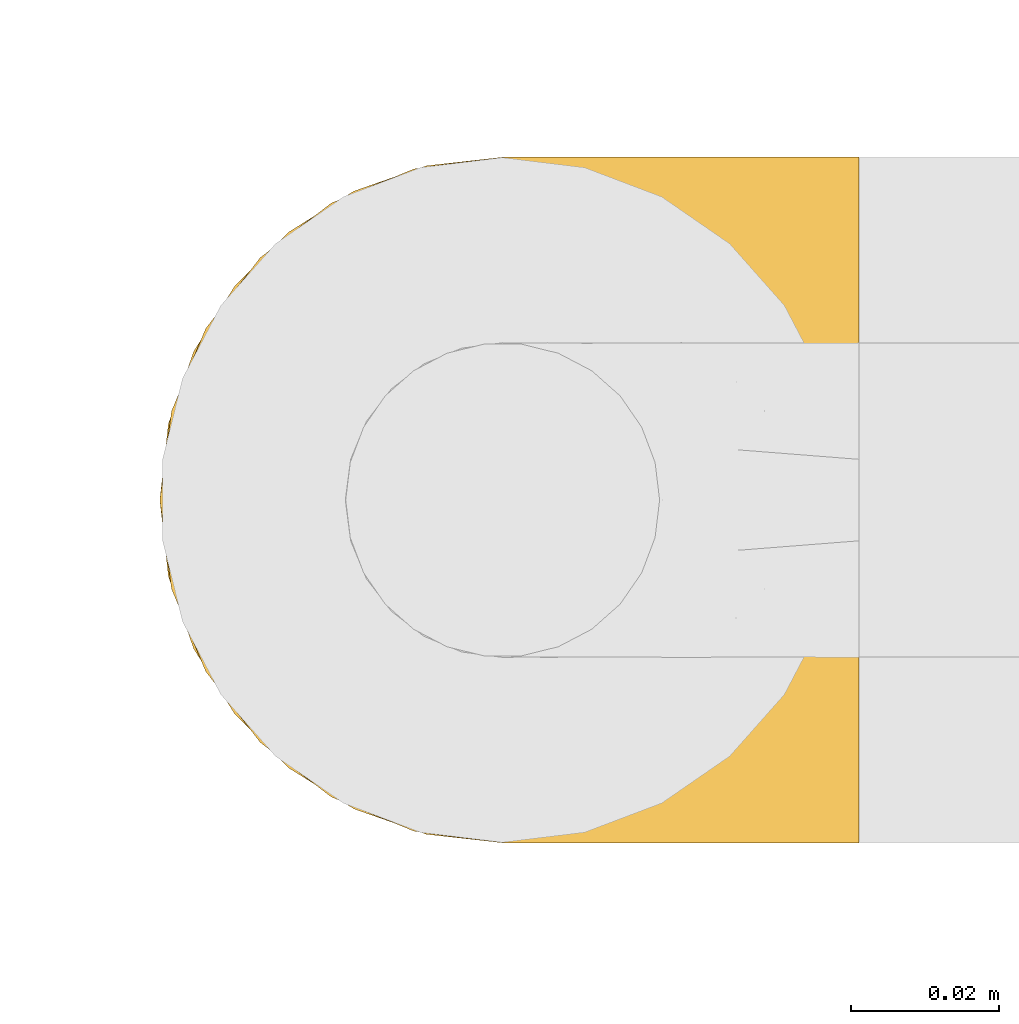
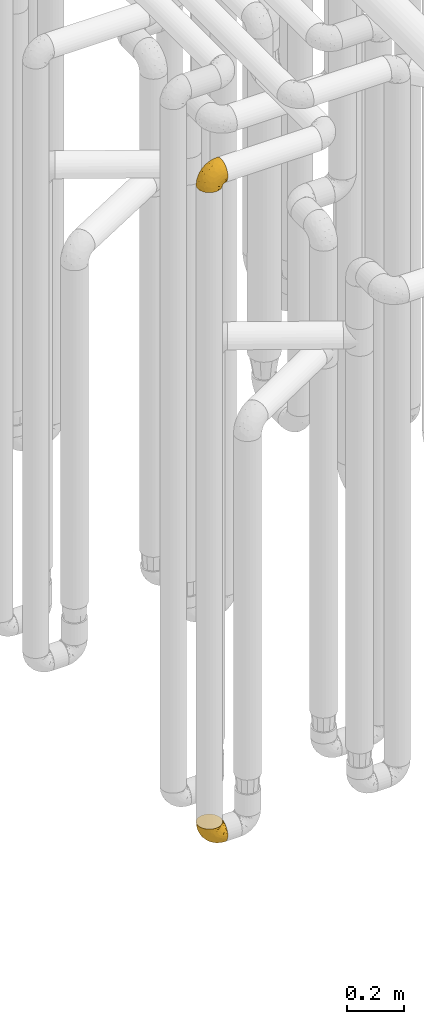
# One storey, part 148 of 827: 2 coverings.
"""IFC2X3 building model written with IfcOpenShell, lengths in millimetres."""

import ifcopenshell
import ifcopenshell.guid

model = None  # the IFC model being written
_history = None  # IfcOwnerHistory: only IFC2X3 demands one
_inside = {}  # id of a spatial element -> (the spatial element, [elements in it])
_under = {}  # id of a project, library or spatial element -> (it, [spatial elements below it])
_declared = {}  # id of a project -> (the project, [libraries it declares])
_typed = {}  # id of a type object -> (the type object, [elements of that type])
_made_of = {}  # id of a material, layer set ... -> (it, [elements and type objects made of it])


def new_model(schema):
    """Start an empty IFC model of exactly this schema.

    Asked for "IFC4X3", IfcOpenShell would pick the latest addendum, in which some entities
    have other attributes; the version numbers below select the first issue.
    IFC2X3 requires an IfcOwnerHistory on every rooted entity: one is made here for all.
    """
    global model, _history
    if schema == "IFC4X3":
        model = ifcopenshell.file(schema_version=(4, 3, 0, 0))
    else:
        model = ifcopenshell.file(schema=schema)
    _inside.clear()
    _under.clear()
    _declared.clear()
    _typed.clear()
    _made_of.clear()
    _history = None
    if model.schema == "IFC2X3":
        org = make("IfcOrganization", Name="unknown")
        user = make(
            "IfcPersonAndOrganization",
            ThePerson=make("IfcPerson", FamilyName="unknown"),
            TheOrganization=org,
        )
        app = make(
            "IfcApplication",
            ApplicationDeveloper=org,
            Version="unknown",
            ApplicationFullName="unknown",
            ApplicationIdentifier="unknown",
        )
        _history = make(
            "IfcOwnerHistory",
            OwningUser=user,
            OwningApplication=app,
            ChangeAction="ADDED",
            CreationDate=0,
        )
    return model


def make(cls, **values):
    """One entity of the class cls with the attributes given. An attribute that is None is left unset."""
    return model.create_entity(
        cls, **{name: value for name, value in values.items() if value is not None}
    )


def entity(cls, *values):
    """Any entity or typed value of the class cls, its attributes in the order of the schema. None: left unset."""
    e = model.create_entity(cls)
    for i, value in enumerate(values):
        if value is not None:
            e[i] = value
    return e


def rooted(cls, **values):
    """An entity with a GlobalId (a new one), such as an element, a storey or a relation."""
    return make(cls, GlobalId=ifcopenshell.guid.new(), OwnerHistory=_history, **values)


def si_unit(unit_type, name, prefix=None):
    """IfcSIUnit, for example si_unit("LENGTHUNIT", "METRE", prefix="MILLI")."""
    return make("IfcSIUnit", UnitType=unit_type, Prefix=prefix, Name=name)


def converted_unit(unit_type, name, factor, base, dimensions=None, offset=None):
    """IfcConversionBasedUnit, such as the inch: factor (a typed value) times the base unit."""
    return make(
        "IfcConversionBasedUnit"
        if offset is None
        else "IfcConversionBasedUnitWithOffset",
        ConversionOffset=offset,
        Dimensions=None
        if dimensions is None
        else entity("IfcDimensionalExponents", *dimensions),
        UnitType=unit_type,
        Name=name,
        ConversionFactor=make(
            "IfcMeasureWithUnit", ValueComponent=factor, UnitComponent=base
        ),
    )


def derived_unit(unit_type, elements):
    """IfcDerivedUnit: a product of units, each with its exponent."""
    return make(
        "IfcDerivedUnit",
        Elements=[
            make("IfcDerivedUnitElement", Unit=unit, Exponent=power)
            for unit, power in elements
        ],
        UnitType=unit_type,
    )


def assignment(units):
    """IfcUnitAssignment: the units of a project."""
    return None if units is None else make("IfcUnitAssignment", Units=units)


def point(xyz):
    """IfcCartesianPoint."""
    return None if xyz is None else make("IfcCartesianPoint", Coordinates=xyz)


def direction(xyz):
    """IfcDirection."""
    return None if xyz is None else make("IfcDirection", DirectionRatios=xyz)


def frame(location, z_axis=None, x_axis=None):
    """IfcAxis2Placement3D, a coordinate frame: its origin and axes. An axis left out is left unset."""
    return make(
        "IfcAxis2Placement3D",
        Location=point(location),
        Axis=direction(z_axis),
        RefDirection=direction(x_axis),
    )


def origin():
    """The frame at (0, 0, 0) with its axes left unset."""
    return frame((0.0, 0.0, 0.0))


def place(relative_to, where):
    """IfcLocalPlacement: puts the frame where relative to a parent placement (None: the world)."""
    return make(
        "IfcLocalPlacement", PlacementRelTo=relative_to, RelativePlacement=where
    )


def context(
    kind, dimensions, precision=None, world=None, true_north=None, identifier=None
):
    """IfcGeometricRepresentationContext, for example the 3D "Model" context."""
    return make(
        "IfcGeometricRepresentationContext",
        ContextIdentifier=identifier,
        ContextType=kind,
        CoordinateSpaceDimension=dimensions,
        Precision=precision,
        WorldCoordinateSystem=world,
        TrueNorth=true_north,
    )


def subcontext(parent, identifier, kind, view, scale=None):
    """IfcGeometricRepresentationSubContext, for example "Body" below "Model"."""
    return make(
        "IfcGeometricRepresentationSubContext",
        ContextIdentifier=identifier,
        ContextType=kind,
        ParentContext=parent,
        TargetScale=scale,
        TargetView=view,
    )


def project(units=None, contexts=None):
    """IfcProject with its units and contexts."""
    return rooted(
        "IfcProject",
        Name="project",
        RepresentationContexts=contexts,
        UnitsInContext=assignment(units),
    )


def spatial(cls, under=None, at=None, **own):
    """A site, building, storey or space (cls), placed at a placement, below another one or the project."""
    s = rooted(cls, ObjectPlacement=at, **own)
    if under is not None:
        _under.setdefault(under.id(), (under, []))[1].append(s)
    return s


def faces_of(points, faces, orient=None, outer=None):
    """IfcFace entities. A face is a list of loops; a loop is a list of indices into points, from 0.

    orient and outer hold one flag for each loop. By default every Orientation is true, the
    first loop of a face is its IfcFaceOuterBound and the others are IfcFaceBound.
    """
    made = []
    for i, loops in enumerate(faces):
        bounds = []
        for j, loop in enumerate(loops):
            is_outer = j == 0 if outer is None else outer[i][j]
            bounds.append(
                make(
                    "IfcFaceOuterBound" if is_outer else "IfcFaceBound",
                    Bound=make("IfcPolyLoop", Polygon=[points[k] for k in loop]),
                    Orientation=True if orient is None else orient[i][j],
                )
            )
        made.append(make("IfcFace", Bounds=bounds))
    return made


def faceted_brep(points, faces, orient=None, outer=None, voids=None):
    """IfcFacetedBrep: a solid bounded by flat faces; with voids (closed shells), ...WithVoids."""
    shared = [point(p) for p in points]
    hull = make("IfcClosedShell", CfsFaces=faces_of(shared, faces, orient, outer))
    if voids is None:
        return make("IfcFacetedBrep", Outer=hull)
    return make(
        "IfcFacetedBrepWithVoids",
        Outer=hull,
        Voids=[
            make(cls, CfsFaces=faces_of(shared, fs, o, b)) for cls, fs, o, b in voids
        ],
    )


def shape(context_of_items, identifier, shape_type, items):
    """IfcShapeRepresentation: the items that make up one representation, for example the "Body"."""
    return make(
        "IfcShapeRepresentation",
        ContextOfItems=context_of_items,
        RepresentationIdentifier=identifier,
        RepresentationType=shape_type,
        Items=items,
    )


def made_of(thing, what):
    """Note that an element or type object is made of a material, layer set ...; save() writes the relation."""
    if what is not None:
        _made_of.setdefault(what.id(), (what, []))[1].append(thing)
    return thing


def element(
    cls,
    number,
    at=None,
    inside=None,
    cuts=None,
    type_object=None,
    material=None,
    context=None,
    identifier="Body",
    shape_type=None,
    held_by="IfcProductDefinitionShape",
    body=None,
    shapes=None,
    **own,
):
    """One element of the class cls, such as IfcWall. Its Tag is "e" and its number.

    at: its placement. inside: the storey or other place that contains it. cuts: it is an
    opening in that element (IfcRelVoidsElement). A single representation is given by context,
    identifier, shape_type and body (its items); several are given by shapes. held_by: the class
    of the entity that holds the representations. save() writes the other relations.
    """
    e = rooted(cls, Tag="e%d" % number, ObjectPlacement=at, **own)
    if body is not None:
        shapes = [shape(context, identifier, shape_type, body)]
    if shapes is not None:
        e.Representation = make(held_by, Representations=shapes)
    if inside is not None:
        _inside.setdefault(inside.id(), (inside, []))[1].append(e)
    if cuts is not None:
        rooted(
            "IfcRelVoidsElement", RelatingBuildingElement=cuts, RelatedOpeningElement=e
        )
    if type_object is not None:
        _typed.setdefault(type_object.id(), (type_object, []))[1].append(e)
    return made_of(e, material)


def aggregate(whole, parts):
    """IfcRelAggregates: a whole, such as a stair, and the parts it consists of."""
    return rooted("IfcRelAggregates", RelatingObject=whole, RelatedObjects=parts)


def save(model, path):
    """Write the relations noted so far, then the file.

    IfcRelAggregates (storeys below a building ...), IfcRelContainedInSpatialStructure (elements
    in a storey), IfcRelDefinesByType, IfcRelAssociatesMaterial and IfcRelDeclares: one each for
    every whole, place, type object, material and project.
    """
    for whole, parts in _under.values():
        aggregate(whole, parts)
    for where, things in _inside.values():
        rooted(
            "IfcRelContainedInSpatialStructure",
            RelatedElements=things,
            RelatingStructure=where,
        )
    for kind, things in _typed.values():
        rooted("IfcRelDefinesByType", RelatedObjects=things, RelatingType=kind)
    for what, things in _made_of.values():
        rooted("IfcRelAssociatesMaterial", RelatedObjects=things, RelatingMaterial=what)
    for by, libraries in _declared.values():
        rooted("IfcRelDeclares", RelatingContext=by, RelatedDefinitions=libraries)
    model.write(path)


model = new_model("IFC2X3")

# Units and contexts
model_context = context("Model", 3, precision=0.01, world=origin(), true_north=direction((6.12303176911189e-17, 1.0)))
body_context = subcontext(model_context, "Body", "Model", "MODEL_VIEW")
ifc_project = project(units=[si_unit("LENGTHUNIT", "METRE", prefix="MILLI"), si_unit("AREAUNIT", "SQUARE_METRE"), si_unit("VOLUMEUNIT", "CUBIC_METRE"), converted_unit("PLANEANGLEUNIT", "DEGREE", entity("IfcRatioMeasure", 0.0174532925199433), si_unit("PLANEANGLEUNIT", "RADIAN"), dimensions=[0, 0, 0, 0, 0, 0, 0]), si_unit("MASSUNIT", "GRAM", prefix="KILO"), derived_unit("MASSDENSITYUNIT", [(si_unit("MASSUNIT", "GRAM", prefix="KILO"), 1), (si_unit("LENGTHUNIT", "METRE"), -3)]), derived_unit("MOMENTOFINERTIAUNIT", [(si_unit("LENGTHUNIT", "METRE"), 4)]), si_unit("TIMEUNIT", "SECOND"), si_unit("FREQUENCYUNIT", "HERTZ"), si_unit("THERMODYNAMICTEMPERATUREUNIT", "DEGREE_CELSIUS"), derived_unit("THERMALTRANSMITTANCEUNIT", [(si_unit("MASSUNIT", "GRAM", prefix="KILO"), 1), (si_unit("THERMODYNAMICTEMPERATUREUNIT", "KELVIN"), -1), (si_unit("TIMEUNIT", "SECOND"), -3)]), derived_unit("VOLUMETRICFLOWRATEUNIT", [(si_unit("LENGTHUNIT", "METRE"), 3), (si_unit("TIMEUNIT", "SECOND"), -1)]), derived_unit("MASSFLOWRATEUNIT", [(si_unit("MASSUNIT", "GRAM", prefix="KILO"), 1), (si_unit("TIMEUNIT", "SECOND"), -1)]), derived_unit("ROTATIONALFREQUENCYUNIT", [(si_unit("TIMEUNIT", "SECOND"), -1)]), si_unit("ELECTRICCURRENTUNIT", "AMPERE"), si_unit("ELECTRICVOLTAGEUNIT", "VOLT"), si_unit("POWERUNIT", "WATT"), si_unit("FORCEUNIT", "NEWTON", prefix="KILO"), si_unit("ILLUMINANCEUNIT", "LUX"), si_unit("LUMINOUSFLUXUNIT", "LUMEN"), si_unit("LUMINOUSINTENSITYUNIT", "CANDELA"), derived_unit("USERDEFINED", [(si_unit("MASSUNIT", "GRAM", prefix="KILO"), -1), (si_unit("LENGTHUNIT", "METRE"), -2), (si_unit("TIMEUNIT", "SECOND"), 3), (si_unit("LUMINOUSFLUXUNIT", "LUMEN"), 1)]), derived_unit("LINEARVELOCITYUNIT", [(si_unit("LENGTHUNIT", "METRE"), 1), (si_unit("TIMEUNIT", "SECOND"), -1)]), si_unit("PRESSUREUNIT", "PASCAL"), derived_unit("USERDEFINED", [(si_unit("LENGTHUNIT", "METRE"), -2), (si_unit("MASSUNIT", "GRAM", prefix="KILO"), 1), (si_unit("TIMEUNIT", "SECOND"), -2)]), derived_unit("LINEARFORCEUNIT", [(si_unit("MASSUNIT", "GRAM", prefix="KILO"), 1), (si_unit("LENGTHUNIT", "METRE"), 1), (si_unit("TIMEUNIT", "SECOND"), -2), (si_unit("LENGTHUNIT", "METRE"), -1)]), derived_unit("PLANARFORCEUNIT", [(si_unit("MASSUNIT", "GRAM", prefix="KILO"), 1), (si_unit("LENGTHUNIT", "METRE"), 1), (si_unit("TIMEUNIT", "SECOND"), -2), (si_unit("LENGTHUNIT", "METRE"), -2)])], contexts=[model_context])

# Site, building, storey
site_placement = place(None, origin())
site = spatial("IfcSite", under=ifc_project, at=site_placement, CompositionType="ELEMENT")
building_placement = place(site_placement, origin())
building = spatial("IfcBuilding", under=site, at=building_placement, CompositionType="ELEMENT")
storey_placement = place(building_placement, frame((0.0, 0.0, 28200.0)))
storey = spatial("IfcBuildingStorey", under=building, at=storey_placement, Name="08", CompositionType="ELEMENT", Elevation=28200.0)

# Coverings
covering_1_placement = place(storey_placement, frame((35077.24, 10309.29, 352.2)))
element("IfcCovering", 1, at=covering_1_placement, inside=storey, Name=":ADSK_", ObjectType=":ADSK_", PredefinedType="INSULATION", context=body_context, shape_type="Brep", body=[
    faceted_brep([(18.98, 83.91, 95.8), (11.67, 76.59, 95.8), (6.17, 67.83, 95.8), (2.75, 58.07, 95.8), (1.6, 47.8, 95.8), (2.75, 37.51, 95.8), (6.17, 27.74, 95.8), (11.68, 18.98, 95.8), (19.0, 11.67, 95.8), (27.76, 6.17, 95.8), (37.52, 2.75, 95.8), (47.8, 1.6, 95.8), (51.94, 2.06, 95.8), (55.01, 2.41, 95.8), (58.08, 2.75, 95.8), (62.96, 4.46, 95.8), (67.85, 6.17, 95.8), (72.23, 8.93, 95.8), (76.61, 11.68, 95.8), (80.26, 15.34, 95.8), (83.92, 19.0, 95.8), (89.42, 27.76, 95.8), (91.13, 32.64, 95.8), (92.84, 37.52, 95.8), (94.0, 47.8, 95.8), (92.84, 58.08, 95.8), (91.13, 62.96, 95.8), (89.42, 67.85, 95.8), (83.91, 76.61, 95.8), (80.25, 80.26, 95.8), (76.59, 83.92, 95.8), (72.21, 86.67, 95.8), (67.83, 89.42, 95.8), (62.95, 91.13, 95.8), (58.07, 92.84, 95.8), (55.0, 93.18, 95.8), (51.94, 93.53, 95.8), (47.8, 94.0, 95.8), (37.51, 92.84, 95.8), (27.74, 89.42, 95.8), (95.8, 47.8, 94.0), (95.8, 35.84, 92.42), (95.8, 24.7, 87.81), (95.8, 19.91, 84.13), (95.8, 15.13, 80.46), (95.8, 11.46, 75.68), (95.8, 7.78, 70.9), (95.8, 5.48, 65.32), (95.8, 3.17, 59.75), (95.8, 2.69, 56.14), (95.8, 2.42, 54.06), (95.8, 2.14, 51.97), (95.8, 1.6, 47.8), (95.8, 3.17, 35.84), (95.8, 7.78, 24.7), (95.8, 15.13, 15.13), (95.8, 24.7, 7.78), (95.8, 35.84, 3.17), (95.8, 47.8, 1.6), (95.8, 59.75, 3.17), (95.8, 70.9, 7.78), (95.8, 80.46, 15.13), (95.8, 87.81, 24.7), (95.8, 92.42, 35.84), (95.8, 94.0, 47.8), (95.8, 93.45, 51.97), (95.8, 92.9, 56.14), (95.8, 92.42, 59.75), (95.8, 90.11, 65.32), (95.8, 87.81, 70.9), (95.8, 84.13, 75.68), (95.8, 80.46, 80.46), (95.8, 75.68, 84.13), (95.8, 70.9, 87.81), (95.8, 59.75, 92.42), (60.58, 71.98, 15.84), (74.11, 63.6, 6.99), (51.59, 59.72, 14.39), (66.69, 47.8, 6.21), (76.19, 55.16, 4.26), (84.43, 47.8, 3.39), (31.2, 63.76, 31.2), (42.88, 72.22, 26.47), (79.41, 74.18, 11.44), (60.7, 92.52, 47.66), (61.85, 94.0, 61.85), (65.75, 94.0, 59.25), (69.64, 94.0, 56.65), (73.53, 94.0, 54.05), (77.43, 94.0, 51.45), (74.59, 82.14, 19.8), (54.72, 80.34, 26.22), (64.18, 87.52, 31.58), (37.94, 79.59, 38.36), (25.89, 78.25, 51.54), (34.73, 85.01, 51.6), (42.89, 90.25, 55.97), (49.83, 93.2, 62.88), (48.58, 87.23, 41.35), (22.41, 85.55, 82.24), (78.69, 93.0, 40.88), (81.64, 89.31, 29.0), (6.22, 61.31, 74.06), (12.11, 56.86, 54.53), (14.81, 68.34, 57.98), (21.61, 65.71, 43.81), (22.41, 56.99, 38.22), (30.12, 72.15, 38.33), (10.01, 70.34, 74.76), (15.36, 78.36, 76.85), (3.39, 47.8, 84.43), (19.59, 47.8, 40.43), (30.01, 47.8, 30.01), (41.19, 93.06, 78.67), (48.54, 94.0, 92.06), (49.28, 94.0, 88.32), (49.82, 94.0, 85.6), (50.37, 94.0, 82.88), (50.91, 94.0, 80.15), (51.45, 94.0, 77.43), (31.61, 89.88, 76.36), (80.15, 94.0, 50.91), (82.88, 94.0, 50.37), (85.6, 94.0, 49.82), (88.32, 94.0, 49.28), (90.19, 94.0, 48.91), (92.06, 94.0, 48.54), (6.21, 47.8, 66.69), (54.05, 94.0, 73.53), (56.65, 94.0, 69.64), (59.25, 94.0, 65.75), (24.66, 83.7, 66.13), (40.43, 47.8, 19.59), (35.17, 55.9, 24.64), (12.9, 47.8, 53.56), (53.56, 47.8, 12.9), (85.34, 81.75, 82.81), (78.44, 86.43, 81.22), (84.37, 79.8, 86.57), (89.05, 69.84, 92.75), (82.76, 79.5, 89.68), (86.31, 88.08, 72.26), (83.73, 91.6, 64.73), (77.31, 92.93, 62.45), (87.78, 92.43, 60.63), (87.91, 93.24, 56.91), (81.29, 93.36, 58.14), (93.97, 57.25, 93.7), (70.76, 89.41, 83.4), (63.67, 92.89, 75.54), (62.62, 92.66, 79.46), (90.64, 79.58, 82.28), (84.08, 86.51, 76.25), (76.28, 86.29, 84.69), (77.45, 83.91, 90.18), (88.72, 90.94, 65.12), (71.28, 91.94, 71.71), (68.09, 91.98, 75.21), (91.07, 82.79, 78.6), (57.47, 93.16, 87.27), (70.34, 88.76, 87.92), (91.35, 73.94, 86.94), (62.99, 91.89, 86.1), (94.52, 47.8, 94.52), (76.47, 92.22, 66.23), (69.96, 88.56, 91.08), (89.86, 87.72, 71.77), (78.94, 88.33, 76.21), (73.51, 92.18, 68.59), (89.62, 71.78, 89.94), (84.09, 9.09, 76.25), (86.3, 7.51, 72.26), (91.06, 12.8, 78.6), (88.32, 1.6, 49.28), (92.06, 1.6, 48.54), (82.88, 1.6, 50.37), (85.6, 1.6, 49.82), (93.97, 38.35, 93.7), (89.63, 23.84, 89.95), (50.37, 1.6, 82.88), (49.82, 1.6, 85.6), (48.54, 1.6, 92.06), (49.28, 1.6, 88.32), (82.77, 16.1, 89.68), (70.36, 6.84, 87.92), (77.31, 2.66, 62.45), (76.47, 3.37, 66.24), (69.64, 1.6, 56.65), (65.75, 1.6, 59.25), (87.78, 3.16, 60.63), (87.91, 2.35, 56.91), (89.06, 25.77, 92.76), (90.65, 16.02, 82.28), (85.35, 13.85, 82.81), (73.53, 1.6, 54.05), (77.43, 1.6, 51.45), (81.29, 2.23, 58.14), (77.46, 11.69, 90.18), (76.29, 9.31, 84.7), (57.47, 2.43, 87.25), (63.71, 2.71, 75.58), (68.11, 3.61, 75.2), (70.77, 6.18, 83.39), (71.31, 3.66, 71.7), (78.46, 9.17, 81.22), (69.52, 6.77, 90.73), (62.64, 2.93, 79.47), (91.35, 21.66, 86.94), (59.25, 1.6, 65.75), (84.6, 16.09, 86.75), (62.98, 3.7, 86.08), (51.45, 1.6, 77.43), (54.05, 1.6, 73.53), (56.65, 1.6, 69.64), (83.73, 3.99, 64.73), (80.15, 1.6, 50.91), (88.72, 4.65, 65.12), (61.85, 1.6, 61.85), (73.56, 3.43, 68.62), (78.96, 7.27, 76.22), (91.36, 9.46, 74.03), (50.91, 1.6, 80.15), (62.87, 2.4, 49.81), (76.19, 40.43, 4.26), (73.57, 13.57, 19.95), (56.07, 11.3, 30.61), (49.77, 18.65, 25.71), (44.73, 27.26, 22.43), (60.58, 23.61, 15.85), (47.64, 3.07, 60.69), (78.32, 2.69, 40.49), (51.59, 35.87, 14.39), (74.11, 31.99, 6.99), (76.04, 6.71, 29.56), (79.41, 21.41, 11.45), (14.82, 27.24, 57.98), (6.22, 34.26, 74.06), (12.12, 38.73, 54.52), (23.51, 26.97, 43.47), (31.2, 31.83, 31.2), (34.96, 23.4, 33.27), (33.86, 6.91, 64.26), (38.94, 3.4, 74.29), (30.23, 5.84, 80.41), (35.17, 39.69, 24.64), (15.85, 17.6, 73.62), (22.59, 10.38, 78.98), (21.56, 20.6, 53.69), (55.94, 5.36, 42.86), (20.67, 35.73, 41.67), (9.19, 24.84, 79.66), (25.79, 13.87, 58.41), (41.16, 9.06, 47.11), (37.95, 15.99, 38.37)], [[[0, 1, 2, 3, 4, 5, 6, 7, 8, 9, 10, 11, 12, 13, 14, 15, 16, 17, 18, 19, 20, 21, 22, 23, 24, 25, 26, 27, 28, 29, 30, 31, 32, 33, 34, 35, 36, 37, 38, 39]], [[40, 41, 42, 43, 44, 45, 46, 47, 48, 49, 50, 51, 52, 53, 54, 55, 56, 57, 58, 59, 60, 61, 62, 63, 64, 65, 66, 67, 68, 69, 70, 71, 72, 73, 74]], [[75, 76, 77]], [[78, 79, 80]], [[77, 81, 82]], [[76, 75, 83]], [[84, 85, 86, 87, 88, 89]], [[90, 91, 92]], [[76, 60, 59]], [[93, 94, 95]], [[90, 62, 61]], [[83, 61, 60]], [[96, 97, 84]], [[98, 93, 95]], [[0, 39, 99]], [[100, 84, 89]], [[62, 101, 63]], [[2, 102, 3]], [[92, 84, 100]], [[103, 102, 104]], [[103, 105, 106]], [[93, 107, 94]], [[1, 108, 2]], [[92, 101, 90]], [[108, 1, 109]], [[102, 110, 3]], [[93, 82, 107]], [[102, 108, 104]], [[111, 106, 112]], [[109, 0, 99]], [[113, 37, 114, 115, 116, 117, 118, 119]], [[120, 38, 113]], [[100, 89, 121, 122, 123, 124, 125, 126, 64]], [[127, 102, 103]], [[97, 119, 128, 129, 130, 85]], [[99, 120, 131]], [[132, 133, 77]], [[59, 80, 79]], [[1, 0, 109]], [[98, 84, 92]], [[94, 109, 131]], [[120, 39, 38]], [[93, 91, 82]], [[104, 94, 105]], [[97, 113, 119]], [[95, 120, 96]], [[83, 90, 61]], [[91, 93, 98]], [[64, 63, 100]], [[100, 63, 101]], [[77, 76, 79]], [[133, 106, 81]], [[84, 97, 85]], [[113, 96, 120]], [[113, 97, 96]], [[37, 113, 38]], [[110, 102, 127]], [[110, 4, 3]], [[103, 111, 134, 127]], [[90, 75, 91]], [[82, 81, 107]], [[91, 75, 82]], [[77, 82, 75]], [[76, 83, 60]], [[90, 83, 75]], [[105, 107, 81]], [[94, 131, 95]], [[105, 94, 107]], [[109, 94, 104]], [[120, 95, 131]], [[98, 95, 96]], [[84, 98, 96]], [[98, 92, 91]], [[106, 105, 81]], [[103, 104, 105]], [[112, 106, 133]], [[103, 106, 111]], [[112, 133, 132]], [[81, 77, 133]], [[77, 78, 135, 132]], [[120, 99, 39]], [[109, 99, 131]], [[59, 58, 80]], [[59, 79, 76]], [[90, 101, 62]], [[100, 101, 92]], [[2, 108, 102]], [[109, 104, 108]], [[78, 77, 79]], [[136, 137, 138]], [[27, 139, 140]], [[141, 142, 143]], [[144, 145, 121]], [[146, 89, 88]], [[147, 139, 25]], [[148, 149, 150]], [[136, 151, 152]], [[147, 40, 74]], [[24, 147, 25]], [[140, 153, 154]], [[33, 116, 34]], [[73, 72, 151]], [[114, 37, 36, 35, 34, 116, 115]], [[146, 155, 144]], [[156, 85, 130]], [[157, 149, 148]], [[151, 158, 152]], [[117, 33, 159]], [[29, 154, 160]], [[161, 74, 73]], [[162, 128, 119]], [[66, 65, 64, 126, 125, 124, 123, 122, 67]], [[163, 147, 24]], [[27, 140, 28]], [[149, 129, 150]], [[139, 27, 26, 25]], [[68, 144, 69]], [[129, 128, 150]], [[164, 87, 86]], [[130, 129, 149]], [[122, 145, 67]], [[154, 153, 148]], [[162, 119, 159]], [[165, 30, 160]], [[150, 160, 148]], [[128, 162, 150]], [[30, 165, 31]], [[145, 144, 68]], [[89, 146, 144]], [[87, 164, 143]], [[166, 155, 142]], [[88, 87, 143]], [[162, 160, 150]], [[160, 30, 29]], [[154, 29, 28]], [[140, 154, 28]], [[160, 154, 148]], [[140, 137, 153]], [[157, 148, 153]], [[156, 130, 157]], [[153, 137, 157]], [[157, 137, 156]], [[167, 137, 136]], [[168, 85, 156]], [[152, 168, 167]], [[167, 168, 156]], [[164, 152, 141]], [[71, 158, 72]], [[152, 167, 136]], [[88, 142, 146]], [[144, 155, 69]], [[146, 142, 155]], [[70, 166, 71]], [[142, 141, 166]], [[70, 69, 155]], [[141, 158, 71]], [[161, 73, 151]], [[138, 137, 140]], [[161, 136, 169]], [[136, 161, 151]], [[74, 161, 169]], [[152, 158, 141]], [[151, 72, 158]], [[168, 152, 164]], [[137, 167, 156]], [[164, 86, 168]], [[85, 168, 86]], [[116, 33, 117]], [[130, 149, 157]], [[67, 145, 68]], [[121, 89, 144]], [[145, 122, 121]], [[40, 147, 163]], [[169, 147, 74]], [[159, 33, 32]], [[162, 159, 32]], [[159, 119, 118, 117]], [[139, 147, 169]], [[139, 169, 138]], [[162, 32, 31]], [[141, 143, 164]], [[88, 143, 142]], [[71, 166, 141]], [[155, 166, 70]], [[139, 138, 140]], [[169, 136, 138]], [[160, 162, 165]], [[162, 31, 165]], [[170, 171, 172]], [[173, 174, 52, 51, 50, 49, 48, 175, 176]], [[177, 178, 41]], [[179, 15, 180]], [[12, 11, 181, 182, 180, 14, 13]], [[183, 21, 20]], [[19, 18, 184]], [[185, 186, 187]], [[186, 188, 187]], [[43, 172, 44]], [[189, 190, 47]], [[23, 22, 21, 191]], [[170, 192, 193]], [[40, 163, 177]], [[194, 195, 196]], [[24, 23, 177]], [[197, 198, 183]], [[199, 15, 179]], [[47, 46, 189]], [[200, 201, 202]], [[201, 203, 204]], [[205, 206, 184]], [[207, 41, 178]], [[16, 15, 199]], [[14, 180, 15]], [[202, 201, 198]], [[208, 201, 200]], [[163, 24, 177]], [[48, 47, 190]], [[196, 195, 189]], [[197, 184, 202]], [[204, 193, 209]], [[210, 211, 212]], [[206, 212, 213]], [[205, 17, 210]], [[184, 206, 202]], [[210, 212, 206]], [[185, 194, 214]], [[189, 215, 190]], [[216, 45, 214]], [[186, 171, 170]], [[189, 216, 196]], [[197, 20, 19]], [[194, 185, 187]], [[197, 183, 20]], [[184, 197, 19]], [[197, 202, 198]], [[206, 200, 202]], [[204, 183, 198]], [[201, 208, 203]], [[203, 208, 217]], [[204, 198, 201]], [[217, 188, 218]], [[193, 219, 170]], [[171, 186, 185]], [[170, 218, 186]], [[170, 219, 218]], [[42, 207, 192]], [[171, 220, 172]], [[216, 189, 46]], [[214, 194, 196]], [[44, 220, 45]], [[214, 196, 216]], [[216, 46, 45]], [[214, 45, 220]], [[192, 43, 42]], [[204, 203, 219]], [[207, 193, 192]], [[209, 193, 178]], [[41, 207, 42]], [[193, 207, 178]], [[43, 192, 172]], [[170, 172, 192]], [[204, 219, 193]], [[219, 203, 218]], [[217, 218, 203]], [[188, 186, 218]], [[206, 213, 200]], [[208, 200, 213]], [[199, 210, 16]], [[215, 189, 195]], [[215, 175, 190]], [[175, 48, 190]], [[199, 179, 221, 211]], [[210, 199, 211]], [[23, 191, 177]], [[40, 177, 41]], [[178, 177, 191]], [[21, 183, 191]], [[209, 191, 183]], [[205, 18, 17]], [[17, 16, 210]], [[171, 185, 214]], [[172, 220, 44]], [[214, 220, 171]], [[191, 209, 178]], [[204, 209, 183]], [[206, 205, 210]], [[18, 205, 184]], [[222, 195, 194, 187, 188, 217]], [[57, 223, 80]], [[224, 225, 226]], [[226, 227, 228]], [[229, 217, 208, 213, 212, 211]], [[230, 52, 174, 173, 176, 175, 215, 195]], [[231, 232, 228]], [[231, 78, 223]], [[223, 57, 232]], [[224, 233, 225]], [[233, 54, 53]], [[234, 232, 56]], [[56, 55, 234]], [[234, 224, 228]], [[235, 236, 237]], [[224, 55, 54]], [[238, 239, 240]], [[52, 230, 53]], [[241, 242, 243]], [[227, 244, 231]], [[11, 10, 242]], [[236, 6, 5]], [[7, 245, 8]], [[8, 246, 9]], [[238, 247, 235]], [[222, 229, 248]], [[242, 211, 221, 179, 180, 182, 181, 11]], [[233, 53, 230]], [[111, 112, 249]], [[250, 6, 236]], [[246, 251, 241]], [[6, 250, 7]], [[127, 236, 110]], [[248, 229, 252]], [[246, 8, 245]], [[235, 245, 250]], [[236, 5, 110]], [[235, 249, 238]], [[237, 236, 127]], [[243, 9, 246]], [[252, 229, 241]], [[56, 232, 57]], [[222, 230, 195]], [[225, 248, 252]], [[248, 233, 230]], [[54, 233, 224]], [[231, 228, 227]], [[244, 132, 231]], [[248, 225, 233]], [[226, 225, 253]], [[235, 250, 236]], [[245, 7, 250]], [[251, 246, 245]], [[243, 246, 241]], [[247, 245, 235]], [[252, 251, 253]], [[229, 222, 217]], [[230, 222, 248]], [[5, 4, 110]], [[237, 127, 134, 111]], [[238, 249, 239]], [[224, 234, 55]], [[232, 234, 228]], [[242, 241, 229]], [[10, 9, 243]], [[211, 242, 229]], [[10, 243, 242]], [[80, 223, 78]], [[80, 58, 57]], [[231, 223, 232]], [[227, 240, 239]], [[224, 226, 228]], [[240, 226, 253]], [[227, 239, 244]], [[226, 240, 227]], [[251, 247, 253]], [[240, 253, 247]], [[249, 235, 237]], [[237, 111, 249]], [[112, 132, 244]], [[112, 244, 249]], [[78, 231, 132, 135]], [[249, 244, 239]], [[247, 238, 240]], [[245, 247, 251]], [[251, 252, 241]], [[225, 252, 253]]]),
])
covering_2_placement = place(storey_placement, frame((35077.24, 10309.29, 3150.4)))
element("IfcCovering", 2, at=covering_2_placement, inside=storey, Name=":ADSK_", ObjectType=":ADSK_", PredefinedType="INSULATION", context=body_context, shape_type="Brep", body=[
    faceted_brep([(95.8, 83.91, 78.41), (95.8, 76.59, 85.72), (95.8, 67.83, 91.22), (95.8, 58.07, 94.64), (95.8, 47.8, 95.8), (95.8, 37.51, 94.64), (95.8, 27.74, 91.22), (95.8, 18.98, 85.71), (95.8, 11.67, 78.39), (95.8, 6.17, 69.63), (95.8, 2.75, 59.87), (95.8, 1.6, 49.6), (95.8, 2.06, 45.45), (95.8, 2.41, 42.38), (95.8, 2.75, 39.31), (95.8, 4.46, 34.43), (95.8, 6.17, 29.54), (95.8, 8.93, 25.16), (95.8, 11.68, 20.78), (95.8, 15.34, 17.13), (95.8, 19.0, 13.47), (95.8, 27.76, 7.97), (95.8, 32.64, 6.26), (95.8, 37.52, 4.55), (95.8, 47.8, 3.4), (95.8, 58.08, 4.55), (95.8, 62.96, 6.26), (95.8, 67.85, 7.97), (95.8, 76.61, 13.48), (95.8, 80.26, 17.14), (95.8, 83.92, 20.8), (95.8, 86.67, 25.18), (95.8, 89.42, 29.56), (95.8, 91.13, 34.44), (95.8, 92.84, 39.32), (95.8, 93.18, 42.39), (95.8, 93.53, 45.45), (95.8, 94.0, 49.6), (95.8, 92.84, 59.88), (95.8, 89.42, 69.65), (94.0, 47.8, 1.6), (92.42, 35.84, 1.6), (87.81, 24.7, 1.6), (84.13, 19.91, 1.6), (80.46, 15.13, 1.6), (75.68, 11.46, 1.6), (70.9, 7.78, 1.6), (65.32, 5.48, 1.6), (59.75, 3.17, 1.6), (56.14, 2.69, 1.6), (54.06, 2.42, 1.6), (51.97, 2.14, 1.6), (47.8, 1.6, 1.6), (35.84, 3.17, 1.6), (24.7, 7.78, 1.6), (15.13, 15.13, 1.6), (7.78, 24.7, 1.6), (3.17, 35.84, 1.6), (1.6, 47.8, 1.6), (3.17, 59.75, 1.6), (7.78, 70.9, 1.6), (15.13, 80.46, 1.6), (24.7, 87.81, 1.6), (35.84, 92.42, 1.6), (47.8, 94.0, 1.6), (51.97, 93.45, 1.6), (56.14, 92.9, 1.6), (59.75, 92.42, 1.6), (65.32, 90.11, 1.6), (70.9, 87.81, 1.6), (75.68, 84.13, 1.6), (80.46, 80.46, 1.6), (84.13, 75.68, 1.6), (87.81, 70.9, 1.6), (92.42, 59.75, 1.6), (15.84, 71.98, 36.81), (6.99, 63.6, 23.28), (14.39, 59.72, 45.8), (6.21, 47.8, 30.7), (4.26, 55.16, 21.2), (3.39, 47.8, 12.96), (31.2, 63.76, 66.19), (26.47, 72.22, 54.51), (11.44, 74.18, 17.98), (47.66, 92.52, 36.69), (61.85, 94.0, 35.54), (59.25, 94.0, 31.64), (56.65, 94.0, 27.75), (54.05, 94.0, 23.86), (51.45, 94.0, 19.96), (19.8, 82.14, 22.8), (26.22, 80.34, 42.67), (31.58, 87.52, 33.21), (38.36, 79.59, 59.45), (51.54, 78.25, 71.5), (51.6, 85.01, 62.66), (55.97, 90.25, 54.5), (62.88, 93.2, 47.57), (41.35, 87.23, 48.81), (82.24, 85.55, 74.98), (40.88, 93.0, 18.7), (29.0, 89.31, 15.75), (74.06, 61.31, 91.17), (54.53, 56.86, 85.28), (57.98, 68.34, 82.58), (43.81, 65.71, 75.78), (38.22, 56.99, 74.98), (38.33, 72.15, 67.27), (74.76, 70.34, 87.38), (76.85, 78.36, 82.04), (84.43, 47.8, 94.0), (40.43, 47.8, 77.8), (30.01, 47.8, 67.38), (78.67, 93.06, 56.2), (92.06, 94.0, 48.85), (88.32, 94.0, 48.11), (85.6, 94.0, 47.57), (82.88, 94.0, 47.03), (80.15, 94.0, 46.48), (77.43, 94.0, 45.94), (76.36, 89.88, 65.78), (50.91, 94.0, 17.24), (50.37, 94.0, 14.51), (49.82, 94.0, 11.79), (49.28, 94.0, 9.07), (48.91, 94.0, 7.2), (48.54, 94.0, 5.33), (66.69, 47.8, 91.18), (73.53, 94.0, 43.34), (69.64, 94.0, 40.74), (65.75, 94.0, 38.14), (66.13, 83.7, 72.73), (19.59, 47.8, 56.96), (24.64, 55.9, 62.23), (53.56, 47.8, 84.49), (12.9, 47.8, 43.83), (82.81, 81.75, 12.05), (81.22, 86.43, 18.95), (86.57, 79.8, 13.02), (92.75, 69.84, 8.34), (89.68, 79.5, 14.63), (72.26, 88.08, 11.09), (64.73, 91.6, 13.66), (62.45, 92.93, 20.08), (60.63, 92.43, 9.61), (56.91, 93.24, 9.48), (58.14, 93.36, 16.1), (93.7, 57.25, 3.42), (83.4, 89.41, 26.63), (75.54, 92.89, 33.72), (79.46, 92.66, 34.77), (82.28, 79.58, 6.75), (76.25, 86.51, 13.31), (84.69, 86.29, 21.11), (90.18, 83.91, 19.94), (86.94, 73.94, 6.04), (65.12, 90.94, 8.67), (71.71, 91.94, 26.11), (75.21, 91.98, 29.3), (78.6, 82.79, 6.32), (87.27, 93.16, 39.92), (87.92, 88.76, 27.05), (86.1, 91.89, 34.4), (94.52, 47.8, 2.87), (66.23, 92.22, 20.92), (91.08, 88.56, 27.43), (71.77, 87.72, 7.54), (76.21, 88.33, 18.45), (68.59, 92.18, 23.88), (89.94, 71.78, 7.77), (76.22, 7.27, 18.43), (81.22, 9.17, 18.93), (71.7, 3.66, 26.08), (49.28, 1.6, 9.07), (48.54, 1.6, 5.33), (50.37, 1.6, 14.51), (49.82, 1.6, 11.79), (93.7, 38.35, 3.42), (89.95, 23.84, 7.76), (82.88, 1.6, 47.03), (85.6, 1.6, 47.57), (92.06, 1.6, 48.85), (88.32, 1.6, 48.11), (89.68, 16.1, 14.62), (87.92, 6.84, 27.03), (62.45, 2.66, 20.08), (66.24, 3.37, 20.92), (56.65, 1.6, 27.75), (59.25, 1.6, 31.64), (78.6, 12.8, 6.33), (60.63, 3.16, 9.61), (56.91, 2.35, 9.48), (92.76, 25.77, 8.33), (76.25, 9.09, 13.3), (82.28, 16.02, 6.74), (82.81, 13.85, 12.04), (54.05, 1.6, 23.86), (51.45, 1.6, 19.96), (58.14, 2.23, 16.1), (90.18, 11.69, 19.93), (84.7, 9.31, 21.1), (87.25, 2.43, 39.92), (75.58, 2.71, 33.68), (75.2, 3.61, 29.28), (83.39, 6.18, 26.62), (90.73, 6.77, 27.87), (79.47, 2.93, 34.75), (86.94, 21.66, 6.04), (65.75, 1.6, 38.14), (86.75, 16.09, 12.79), (86.08, 3.7, 34.41), (77.43, 1.6, 45.94), (73.53, 1.6, 43.34), (69.64, 1.6, 40.74), (64.73, 3.99, 13.66), (50.91, 1.6, 17.24), (65.12, 4.65, 8.67), (72.26, 7.51, 11.09), (61.85, 1.6, 35.54), (68.62, 3.43, 23.83), (74.03, 9.46, 6.03), (80.15, 1.6, 46.48), (49.81, 2.4, 34.52), (4.26, 40.43, 21.2), (19.95, 13.57, 23.82), (30.61, 11.3, 41.32), (25.71, 18.65, 47.62), (22.43, 27.26, 52.66), (15.85, 23.61, 36.81), (60.69, 3.07, 49.75), (40.49, 2.69, 19.07), (14.39, 35.87, 45.8), (6.99, 31.99, 23.28), (29.56, 6.71, 21.35), (11.45, 21.41, 17.98), (57.98, 27.24, 82.57), (74.06, 34.26, 91.17), (54.52, 38.73, 85.27), (43.47, 26.97, 73.89), (31.2, 31.83, 66.19), (33.27, 23.4, 62.43), (64.26, 6.91, 63.53), (74.29, 3.4, 58.45), (80.41, 5.84, 67.16), (24.64, 39.69, 62.22), (73.62, 17.6, 81.54), (78.98, 10.38, 74.8), (53.69, 20.6, 75.83), (42.86, 5.36, 41.45), (41.67, 35.73, 76.72), (79.66, 24.84, 88.2), (58.41, 13.87, 71.6), (47.11, 9.06, 56.23), (38.37, 15.99, 59.44)], [[[0, 1, 2, 3, 4, 5, 6, 7, 8, 9, 10, 11, 12, 13, 14, 15, 16, 17, 18, 19, 20, 21, 22, 23, 24, 25, 26, 27, 28, 29, 30, 31, 32, 33, 34, 35, 36, 37, 38, 39]], [[40, 41, 42, 43, 44, 45, 46, 47, 48, 49, 50, 51, 52, 53, 54, 55, 56, 57, 58, 59, 60, 61, 62, 63, 64, 65, 66, 67, 68, 69, 70, 71, 72, 73, 74]], [[75, 76, 77]], [[78, 79, 80]], [[77, 81, 82]], [[76, 75, 83]], [[84, 85, 86, 87, 88, 89]], [[90, 91, 92]], [[76, 60, 59]], [[93, 94, 95]], [[90, 62, 61]], [[83, 61, 60]], [[96, 97, 84]], [[98, 93, 95]], [[0, 39, 99]], [[100, 84, 89]], [[62, 101, 63]], [[2, 102, 3]], [[92, 84, 100]], [[103, 102, 104]], [[103, 105, 106]], [[93, 107, 94]], [[1, 108, 2]], [[92, 101, 90]], [[108, 1, 109]], [[102, 110, 3]], [[93, 82, 107]], [[102, 108, 104]], [[111, 106, 112]], [[109, 0, 99]], [[113, 37, 114, 115, 116, 117, 118, 119]], [[120, 38, 113]], [[100, 89, 121, 122, 123, 124, 125, 126, 64]], [[127, 102, 103]], [[97, 119, 128, 129, 130, 85]], [[99, 120, 131]], [[132, 133, 77]], [[59, 80, 79]], [[1, 0, 109]], [[98, 84, 92]], [[94, 109, 131]], [[120, 39, 38]], [[93, 91, 82]], [[104, 94, 105]], [[97, 113, 119]], [[95, 120, 96]], [[83, 90, 61]], [[91, 93, 98]], [[64, 63, 100]], [[100, 63, 101]], [[77, 76, 79]], [[133, 106, 81]], [[84, 97, 85]], [[113, 96, 120]], [[113, 97, 96]], [[37, 113, 38]], [[110, 102, 127]], [[110, 4, 3]], [[103, 111, 134, 127]], [[90, 75, 91]], [[82, 81, 107]], [[91, 75, 82]], [[77, 82, 75]], [[76, 83, 60]], [[90, 83, 75]], [[105, 107, 81]], [[94, 131, 95]], [[105, 94, 107]], [[109, 94, 104]], [[120, 95, 131]], [[98, 95, 96]], [[84, 98, 96]], [[98, 92, 91]], [[106, 105, 81]], [[103, 104, 105]], [[112, 106, 133]], [[103, 106, 111]], [[112, 133, 132]], [[81, 77, 133]], [[77, 78, 135, 132]], [[120, 99, 39]], [[109, 99, 131]], [[59, 58, 80]], [[59, 79, 76]], [[90, 101, 62]], [[100, 101, 92]], [[2, 108, 102]], [[109, 104, 108]], [[78, 77, 79]], [[136, 137, 138]], [[27, 139, 140]], [[141, 142, 143]], [[144, 145, 121]], [[146, 89, 88]], [[147, 139, 25]], [[148, 149, 150]], [[136, 151, 152]], [[147, 40, 74]], [[24, 147, 25]], [[140, 153, 154]], [[33, 116, 34]], [[73, 151, 155]], [[114, 37, 36, 35, 34, 116, 115]], [[146, 156, 144]], [[157, 85, 130]], [[158, 149, 148]], [[151, 159, 152]], [[117, 33, 160]], [[29, 154, 161]], [[155, 74, 73]], [[162, 128, 119]], [[66, 65, 64, 126, 125, 124, 123, 122, 67]], [[163, 147, 24]], [[27, 140, 28]], [[149, 129, 150]], [[139, 27, 26, 25]], [[68, 144, 69]], [[129, 128, 150]], [[164, 87, 86]], [[130, 129, 149]], [[122, 145, 67]], [[154, 153, 148]], [[162, 119, 160]], [[165, 30, 161]], [[150, 161, 148]], [[128, 162, 150]], [[30, 165, 31]], [[145, 144, 68]], [[89, 146, 144]], [[87, 164, 143]], [[166, 156, 142]], [[88, 87, 143]], [[162, 161, 150]], [[161, 30, 29]], [[154, 29, 28]], [[140, 154, 28]], [[161, 154, 148]], [[140, 137, 153]], [[158, 148, 153]], [[157, 130, 158]], [[153, 137, 158]], [[158, 137, 157]], [[167, 137, 136]], [[168, 85, 157]], [[152, 168, 167]], [[167, 168, 157]], [[164, 152, 141]], [[151, 73, 72]], [[159, 72, 71]], [[88, 142, 146]], [[144, 156, 69]], [[146, 142, 156]], [[70, 166, 71]], [[142, 141, 166]], [[70, 69, 156]], [[141, 159, 71]], [[167, 136, 152]], [[138, 137, 140]], [[155, 136, 169]], [[136, 155, 151]], [[74, 155, 169]], [[152, 159, 141]], [[151, 72, 159]], [[168, 152, 164]], [[137, 167, 157]], [[164, 86, 168]], [[85, 168, 86]], [[116, 33, 117]], [[130, 149, 158]], [[67, 145, 68]], [[121, 89, 144]], [[145, 122, 121]], [[40, 147, 163]], [[169, 147, 74]], [[160, 33, 32]], [[162, 160, 32]], [[160, 119, 118, 117]], [[139, 147, 169]], [[139, 169, 138]], [[162, 32, 31]], [[141, 143, 164]], [[88, 143, 142]], [[71, 166, 141]], [[156, 166, 70]], [[139, 138, 140]], [[169, 136, 138]], [[161, 162, 165]], [[162, 31, 165]], [[170, 171, 172]], [[173, 174, 52, 51, 50, 49, 48, 175, 176]], [[177, 178, 41]], [[179, 15, 180]], [[12, 11, 181, 182, 180, 14, 13]], [[183, 21, 20]], [[19, 18, 184]], [[185, 186, 187]], [[186, 188, 187]], [[43, 189, 44]], [[190, 191, 47]], [[23, 22, 21, 192]], [[193, 194, 195]], [[40, 163, 177]], [[196, 197, 198]], [[24, 23, 177]], [[199, 200, 183]], [[201, 15, 179]], [[47, 46, 190]], [[202, 203, 204]], [[203, 172, 171]], [[205, 206, 184]], [[207, 41, 178]], [[16, 15, 201]], [[14, 180, 15]], [[204, 203, 200]], [[208, 203, 202]], [[163, 24, 177]], [[48, 47, 191]], [[198, 197, 190]], [[199, 184, 204]], [[171, 195, 209]], [[210, 211, 212]], [[206, 212, 213]], [[205, 17, 210]], [[184, 206, 204]], [[210, 212, 206]], [[185, 196, 214]], [[190, 215, 191]], [[216, 45, 214]], [[186, 217, 193]], [[190, 216, 198]], [[199, 20, 19]], [[196, 185, 187]], [[199, 183, 20]], [[184, 199, 19]], [[199, 204, 200]], [[206, 202, 204]], [[171, 183, 200]], [[203, 208, 172]], [[172, 208, 218]], [[171, 200, 203]], [[218, 188, 219]], [[195, 170, 193]], [[217, 186, 185]], [[193, 219, 186]], [[193, 170, 219]], [[207, 194, 42]], [[217, 220, 189]], [[216, 190, 46]], [[214, 196, 198]], [[44, 220, 45]], [[214, 198, 216]], [[216, 46, 45]], [[214, 45, 220]], [[42, 194, 43]], [[189, 193, 217]], [[207, 195, 194]], [[209, 195, 178]], [[41, 207, 42]], [[195, 207, 178]], [[43, 194, 189]], [[193, 189, 194]], [[171, 170, 195]], [[170, 172, 219]], [[218, 219, 172]], [[188, 186, 219]], [[206, 213, 202]], [[208, 202, 213]], [[201, 210, 16]], [[215, 190, 197]], [[215, 175, 191]], [[175, 48, 191]], [[201, 179, 221, 211]], [[210, 201, 211]], [[23, 192, 177]], [[40, 177, 41]], [[183, 209, 192]], [[183, 192, 21]], [[192, 178, 177]], [[205, 18, 17]], [[17, 16, 210]], [[217, 185, 214]], [[189, 220, 44]], [[214, 220, 217]], [[192, 209, 178]], [[171, 209, 183]], [[206, 205, 210]], [[18, 205, 184]], [[222, 197, 196, 187, 188, 218]], [[57, 223, 80]], [[224, 225, 226]], [[226, 227, 228]], [[229, 218, 208, 213, 212, 211]], [[230, 52, 174, 173, 176, 175, 215, 197]], [[231, 232, 228]], [[231, 78, 223]], [[223, 57, 232]], [[224, 233, 225]], [[233, 54, 53]], [[234, 232, 56]], [[56, 55, 234]], [[234, 224, 228]], [[235, 236, 237]], [[224, 55, 54]], [[238, 239, 240]], [[52, 230, 53]], [[241, 242, 243]], [[231, 227, 244]], [[11, 10, 242]], [[236, 6, 5]], [[7, 245, 8]], [[8, 246, 9]], [[238, 247, 235]], [[222, 229, 248]], [[242, 211, 221, 179, 180, 182, 181, 11]], [[233, 53, 230]], [[111, 112, 249]], [[250, 6, 236]], [[246, 251, 241]], [[6, 250, 7]], [[127, 236, 110]], [[248, 229, 252]], [[246, 8, 245]], [[235, 245, 250]], [[236, 5, 110]], [[235, 249, 238]], [[237, 236, 127]], [[243, 9, 246]], [[252, 229, 241]], [[56, 232, 57]], [[222, 230, 197]], [[225, 248, 252]], [[248, 233, 230]], [[54, 233, 224]], [[231, 228, 227]], [[244, 132, 231]], [[248, 225, 233]], [[226, 225, 253]], [[235, 250, 236]], [[245, 7, 250]], [[251, 246, 245]], [[243, 246, 241]], [[247, 245, 235]], [[252, 251, 253]], [[229, 222, 218]], [[230, 222, 248]], [[5, 4, 110]], [[237, 127, 134, 111]], [[238, 249, 239]], [[224, 234, 55]], [[232, 234, 228]], [[242, 241, 229]], [[10, 9, 243]], [[211, 242, 229]], [[10, 243, 242]], [[80, 223, 78]], [[80, 58, 57]], [[231, 223, 232]], [[227, 240, 239]], [[224, 226, 228]], [[240, 226, 253]], [[227, 239, 244]], [[226, 240, 227]], [[251, 247, 253]], [[240, 253, 247]], [[249, 235, 237]], [[237, 111, 249]], [[244, 239, 249]], [[112, 244, 249]], [[135, 78, 231, 132]], [[112, 132, 244]], [[247, 238, 240]], [[245, 247, 251]], [[251, 252, 241]], [[225, 252, 253]]]),
])

save(model, "model.ifc")
